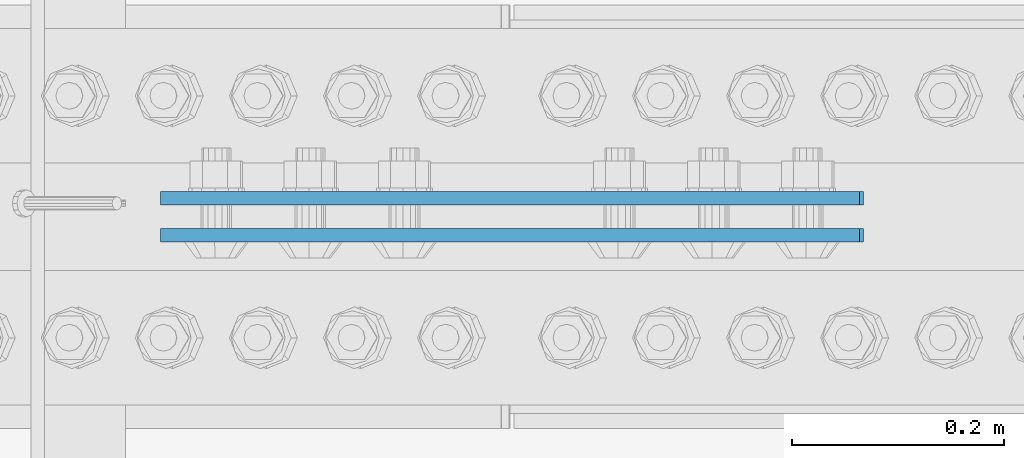
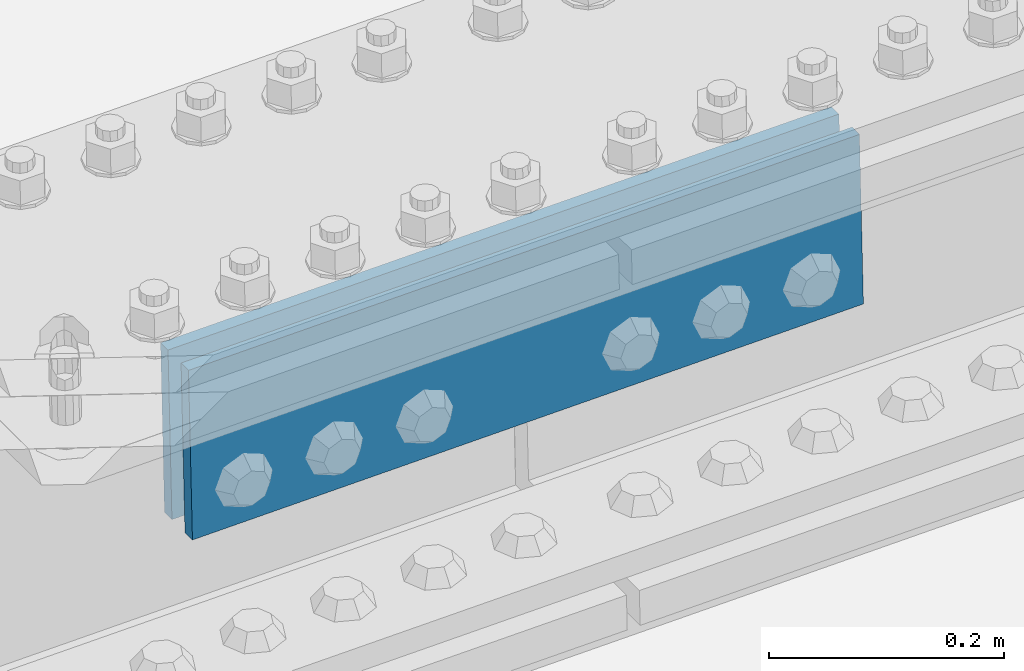
# One storey, part 2347 of 3843: 2 beams, 1 element without a shape of its own.
"""IFC2X3 building model written with IfcOpenShell, lengths in millimetres."""

from ifc_helpers import new_model, si_unit, frame, origin_with_axes, place, context, subcontext, project, spatial, faceted_brep, material, type_object, element, aggregate, save


model = new_model("IFC2X3")

# Units and contexts
model_context = context("Model", 3, precision=1e-05, world=origin_with_axes())
body_context = subcontext(model_context, "Body", "Model", "MODEL_VIEW")
ifc_project = project(units=[si_unit("LENGTHUNIT", "METRE", prefix="MILLI"), si_unit("AREAUNIT", "SQUARE_METRE"), si_unit("VOLUMEUNIT", "CUBIC_METRE"), si_unit("MASSUNIT", "GRAM", prefix="KILO"), si_unit("TIMEUNIT", "SECOND"), si_unit("PLANEANGLEUNIT", "RADIAN"), si_unit("SOLIDANGLEUNIT", "STERADIAN"), si_unit("THERMODYNAMICTEMPERATUREUNIT", "DEGREE_CELSIUS"), si_unit("LUMINOUSINTENSITYUNIT", "LUMEN")], contexts=[model_context])

# Site, building, storey
site_placement = place(None, origin_with_axes())
site = spatial("IfcSite", under=ifc_project, at=site_placement, CompositionType="ELEMENT")
building_placement = place(site_placement, origin_with_axes())
building = spatial("IfcBuilding", under=site, at=building_placement, Name="Undefined", CompositionType="ELEMENT")
storey_placement = place(building_placement, origin_with_axes())
storey = spatial("IfcBuildingStorey", under=building, at=storey_placement, Name="Undefined", CompositionType="ELEMENT", Elevation=0.0)

# Assembly, beams
assembly_placement = place(storey_placement, origin_with_axes())
assembly = element("IfcElementAssembly", 1, at=assembly_placement, inside=storey, Name="BEAM", AssemblyPlace="NOTDEFINED", PredefinedType="RIGID_FRAME")
ifc_material = material(Name="STEEL/A572-50")
beam_type = type_object("IfcBeamType", PredefinedType="NOTDEFINED")
beam_1_placement = place(assembly_placement, frame((65841.0030077449, 50576.1625, 45937.8578099164), z_axis=(0.0217479709980253, 0.0, -0.99976348490904), x_axis=(-0.99976348490904, 0.0, -0.0217479709980245)))
beam_1 = element("IfcBeam", 2, at=beam_1_placement, type_object=beam_type, material=ifc_material, Name="PLATE", context=body_context, shape_type="Brep", body=[
    faceted_brep([(1.45519152283669e-11, 6.35000000000582, -88.8999999998996), (0.0, 6.34999999999854, 88.9000015258789), (660.399999982677, 6.35000000000582, 88.8999999999651), (660.399999982707, 6.35000000000582, -88.8999999998268), (0.0, -6.34999999999854, 88.9000015258789), (660.399999982677, -6.35000000000582, 88.8999999999651), (1.45519152283669e-11, -6.35000000000582, -88.8999999998996), (660.399999982707, -6.35000000000582, -88.8999999998268)], [[[0, 1, 2, 3]], [[1, 4, 5, 2]], [[4, 6, 7, 5]], [[6, 0, 3, 7]], [[5, 7, 3, 2]], [[6, 4, 1, 0]]]),
])
beam_2_placement = place(assembly_placement, frame((65841.0030077449, 50541.2375, 45937.8578099164), z_axis=(0.0217479709980253, 0.0, -0.99976348490904), x_axis=(-0.99976348490904, 0.0, -0.0217479709980245)))
beam_2 = element("IfcBeam", 3, at=beam_2_placement, type_object=beam_type, material=ifc_material, Name="PLATE", context=body_context, shape_type="Brep", body=[
    faceted_brep([(1.45519152283669e-11, 6.35000000000582, -88.8999999998996), (0.0, 6.34999999999854, 88.9000015258789), (660.399999982677, 6.35000000000582, 88.8999999999651), (660.399999982707, 6.35000000000582, -88.8999999998268), (0.0, -6.34999999999854, 88.9000015258789), (660.399999982677, -6.35000000000582, 88.8999999999651), (1.45519152283669e-11, -6.35000000000582, -88.8999999998996), (660.399999982707, -6.35000000000582, -88.8999999998268)], [[[0, 1, 2, 3]], [[1, 4, 5, 2]], [[4, 6, 7, 5]], [[6, 0, 3, 7]], [[5, 7, 3, 2]], [[6, 4, 1, 0]]]),
])
aggregate(assembly, [beam_1, beam_2])

save(model, "model.ifc")
